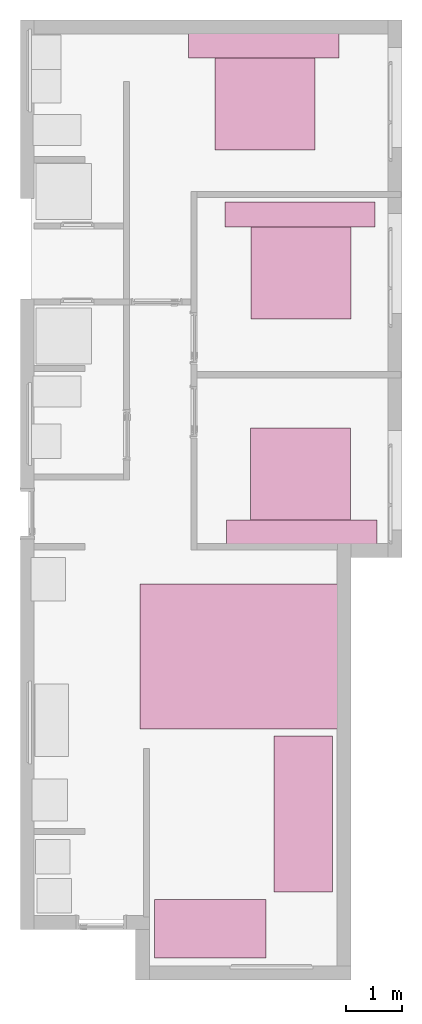
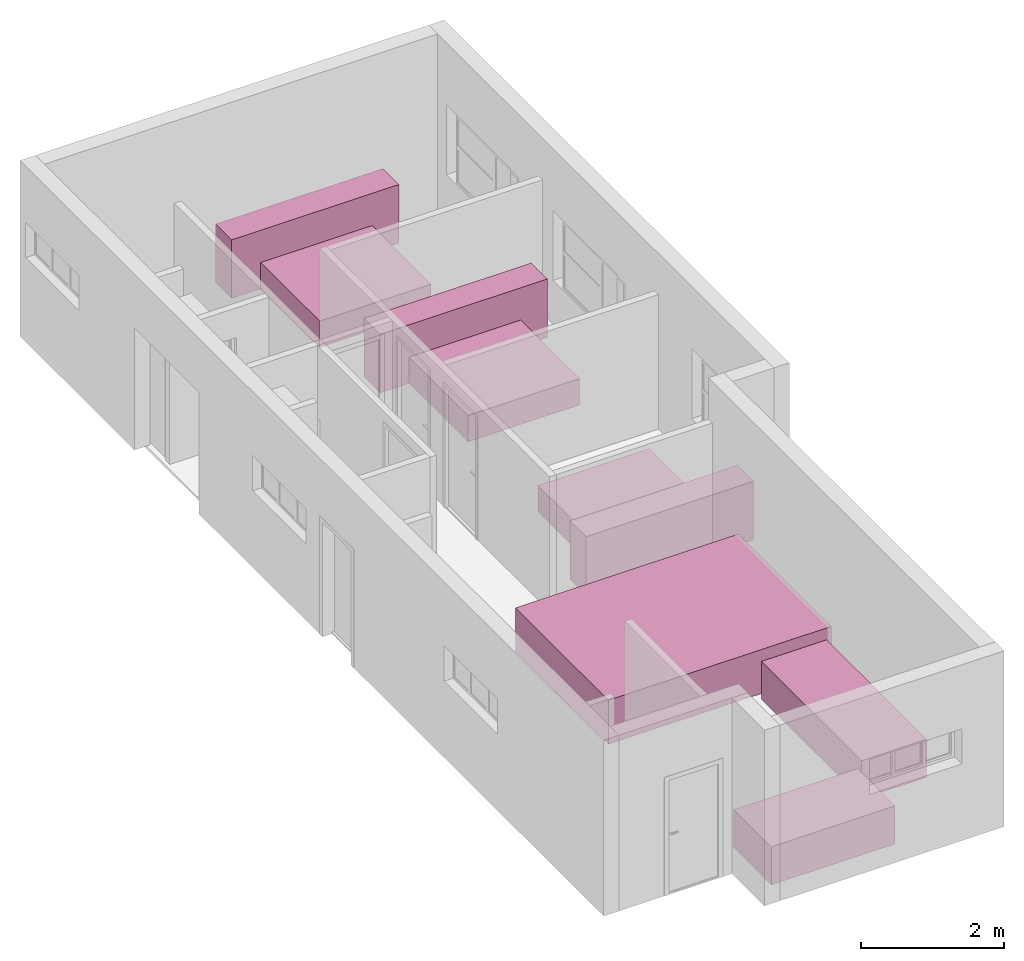
# One storey, part 10 of 10: 6 furniture elements.
"""IFC4 building model written with IfcOpenShell, lengths in millimetres."""

from ifc_helpers import new_model, entity, si_unit, converted_unit, frame, origin_with_axes, origin_2d_with_axis, place, context, subcontext, project, spatial, polygons, source, transform, mapped, type_object, type_shapes, element, save


model = new_model("IFC4")

# Units and contexts
model_context = context("Model", 3, precision=1e-05, world=origin_with_axes())
plan_context = context("Plan", 2, precision=1e-05, world=origin_2d_with_axis())
body_context = subcontext(model_context, "Body", "Model", "MODEL_VIEW")
ifc_project = project(units=[si_unit("VOLUMEUNIT", "CUBIC_METRE"), si_unit("LENGTHUNIT", "METRE", prefix="MILLI"), converted_unit("PLANEANGLEUNIT", "degree", entity("IfcReal", 0.0174532925199433), si_unit("PLANEANGLEUNIT", "RADIAN"), dimensions=[0, 0, 0, 0, 0, 0, 0]), si_unit("AREAUNIT", "SQUARE_METRE")], contexts=[model_context, plan_context])

# Site, building, storey
site_placement = place(None, origin_with_axes())
site = spatial("IfcSite", under=ifc_project, at=site_placement)
building_placement = place(site_placement, origin_with_axes())
building = spatial("IfcBuilding", under=site, at=building_placement, Name="Building")
storey_placement = place(building_placement, origin_with_axes())
storey = spatial("IfcBuildingStorey", under=building, at=storey_placement, Name="0-Ground Floor")

# Furniture
furniture_type_1 = type_object("IfcFurnitureType", Name="2 seater", AssemblyPlace="NOTDEFINED", PredefinedType="SOFA")
shared_shape_1 = source(origin_with_axes(), body_context, "Body", "Tessellation", [
    polygons([(1049.99987792969, 2000.00012207031, 649.999938964844), (1049.99987792969, 2000.00012207031, 0.0), (1049.99987792969, 0.000114087008114439, 649.999938964844), (1049.99987792969, 0.000114087008114439, 0.0), (-0.000357627839548513, 0.000114087008114439, 0.0), (-0.000357627839548513, 2000.00012207031, 649.999938964844), (-0.000357627839548513, 2000.00012207031, 0.0), (-0.000357627839548513, 0.000114087008114439, 649.999938964844)], [[[1, 6, 8, 3]], [[7, 2, 4, 5]], [[4, 3, 8, 5]], [[2, 1, 3, 4]], [[7, 6, 1, 2]], [[5, 8, 6, 7]]], closed=True),
])
type_shapes(furniture_type_1, [shared_shape_1])
furniture_1_placement = place(storey_placement, frame((5751.81770324707, 1366.0569190979, 0.0), z_axis=(0.0, 0.0, 1.0), x_axis=(-4.37113882867379e-08, 0.999999999999999, 0.0)))
element("IfcFurniture", 1, at=furniture_1_placement, inside=storey, type_object=furniture_type_1, Name="Furniture", context=body_context, shape_type="MappedRepresentation", body=[
    mapped(shared_shape_1, transform((0.0, 0.0, 0.0), x_axis=(1.0, 0.0, 0.0), y_axis=(0.0, 1.0, 0.0), z_axis=(0.0, 0.0, 1.0), scale=1.0)),
])
furniture_type_2 = type_object("IfcFurnitureType", Name="3 seater", AssemblyPlace="NOTDEFINED", PredefinedType="SOFA")
shared_shape_2 = source(origin_with_axes(), body_context, "Body", "Tessellation", [
    polygons([(1049.99987792969, 2800.0, 649.999938964844), (1049.99987792969, 2800.0, 0.0), (1049.99987792969, 0.000114087008114439, 649.999938964844), (1049.99987792969, 0.000114087008114439, 0.0), (-0.000357627839548513, 0.000114087008114439, 0.0), (-0.000357627839548513, 2800.0, 649.999938964844), (-0.000357627839548513, 2800.0, 0.0), (-0.000357627839548513, 0.000114087008114439, 649.999938964844)], [[[1, 6, 8, 3]], [[7, 2, 4, 5]], [[4, 3, 8, 5]], [[2, 1, 3, 4]], [[7, 6, 1, 2]], [[5, 8, 6, 7]]], closed=True),
])
type_shapes(furniture_type_2, [shared_shape_2])
furniture_2_placement = place(storey_placement, frame((5895.61319351196, 2552.36911773682, 0.0), z_axis=(0.0, 0.0, 1.0), x_axis=(1.0, 0.0, 0.0)))
element("IfcFurniture", 2, at=furniture_2_placement, inside=storey, type_object=furniture_type_2, Name="Furniture", context=body_context, shape_type="MappedRepresentation", body=[
    mapped(shared_shape_2, transform((0.0, 0.0, 0.0), x_axis=(1.0, 0.0, 0.0), y_axis=(0.0, 1.0, 0.0), z_axis=(0.0, 0.0, 1.0), scale=1.0)),
])
furniture_type_3 = type_object("IfcFurnitureType", Name="6", AssemblyPlace="NOTDEFINED", PredefinedType="TABLE")
shared_shape_3 = source(origin_with_axes(), body_context, "Body", "Tessellation", [
    polygons([(2599.99975585938, 3600.0, 749.999816894531), (2599.99975585938, 0.000114087000838481, 749.999816894531), (-0.000357627810444683, 3600.0, 749.999816894531), (-0.000357627810444683, 0.000114087000838481, 749.999816894531), (-0.000357627810444683, 0.000114087000838481, 0.0), (-0.000357627810444683, 3600.0, 0.0), (2599.99975585938, 3600.0, 0.0), (2599.99975585938, 0.000114087000838481, 0.0)], [[[1, 2, 8, 7]], [[3, 4, 2, 1]], [[3, 1, 7, 6]], [[4, 3, 6, 5]], [[4, 5, 8, 2]], [[8, 5, 6, 7]]], closed=True),
])
type_shapes(furniture_type_3, [shared_shape_3])
furniture_3_placement = place(storey_placement, frame((3496.1097240448, 8076.61819458008, 0.0), z_axis=(0.0, 0.0, 1.0), x_axis=(7.54979012640431e-08, -0.999999999999997, 0.0)))
element("IfcFurniture", 3, at=furniture_3_placement, inside=storey, type_object=furniture_type_3, Name="Furniture", context=body_context, shape_type="MappedRepresentation", body=[
    mapped(shared_shape_3, transform((0.0, 0.0, 0.0), x_axis=(1.0, 0.0, 0.0), y_axis=(0.0, 1.0, 0.0), z_axis=(0.0, 0.0, 1.0), scale=1.0)),
])
furniture_type_4 = type_object("IfcFurnitureType", Name="King Size", AssemblyPlace="NOTDEFINED", PredefinedType="BED")
shared_shape_4 = source(origin_with_axes(), body_context, "Body", "Tessellation", [
    polygons([(2.91689348220825, 2001.2890625, 449.999877929688), (1802.91625976562, 2001.2890625, 449.999877929688), (2.91689348220825, 2001.2890625, 0.0), (1802.91625976562, 2001.2890625, 0.0), (1802.91625976562, 1.28962075710297, 449.999877929688), (1802.91625976562, 1.28962075710297, 0.0), (2.91689348220825, 1.28962075710297, 0.0), (2.91689348220825, 1.28962075710297, 449.999877929688), (-465.363525390625, 1649.72766113281, 0.0), (-465.363525390625, 1649.72766113281, 999.999816894531), (-465.363525390625, 2099.72778320312, 0.0), (-465.363525390625, 2099.72778320312, 999.999816894531), (2234.63598632812, 2099.72778320312, 999.999816894531), (2234.63598632812, 2099.72778320312, 0.0), (2234.63598632812, 1649.72766113281, 0.0), (2234.63598632812, 1649.72766113281, 999.999816894531)], [[[2, 3, 1]], [[2, 4, 3]], [[5, 4, 2]], [[5, 6, 4]], [[3, 4, 6]], [[3, 6, 7]], [[1, 8, 2]], [[2, 8, 5]], [[6, 5, 8]], [[6, 8, 7]], [[7, 8, 1]], [[7, 1, 3]], [[9, 10, 11]], [[11, 10, 12]], [[13, 14, 11]], [[13, 11, 12]], [[13, 15, 14]], [[16, 15, 13]], [[15, 16, 10]], [[15, 10, 9]], [[11, 14, 15]], [[11, 15, 9]], [[13, 12, 16]], [[12, 10, 16]]], closed=True),
])
type_shapes(furniture_type_4, [shared_shape_4])
for number, where, z_axis, x_axis, name in (
    (4, (4832.11326599121, 15868.7782287598, 0.0), (0.0, 0.0, 1.0), (0.999999999999993, -1.1920928955078e-07, 0.0), "Furniture"),
    (5, (5479.19273376465, 12836.856842041, 0.0), (0.0, 0.0, 1.0), (0.999999999999993, -1.1920928955078e-07, 0.0), "Furniture"),
    (6, (7276.63564682007, 10875.9098052979, 0.0), (0.0, 0.0, 1.0), (-0.999999999999989, 1.50995802528085e-07, 0.0), "Furniture"),
):
    element("IfcFurniture", number, at=place(storey_placement, frame(where, z_axis=z_axis, x_axis=x_axis)), inside=storey, type_object=furniture_type_4, Name=name, context=body_context, shape_type="MappedRepresentation", body=[
        mapped(shared_shape_4, transform((0.0, 0.0, 0.0), x_axis=(1.0, 0.0, 0.0), y_axis=(0.0, 1.0, 0.0), z_axis=(0.0, 0.0, 1.0), scale=1.0)),
    ])

save(model, "model.ifc")
